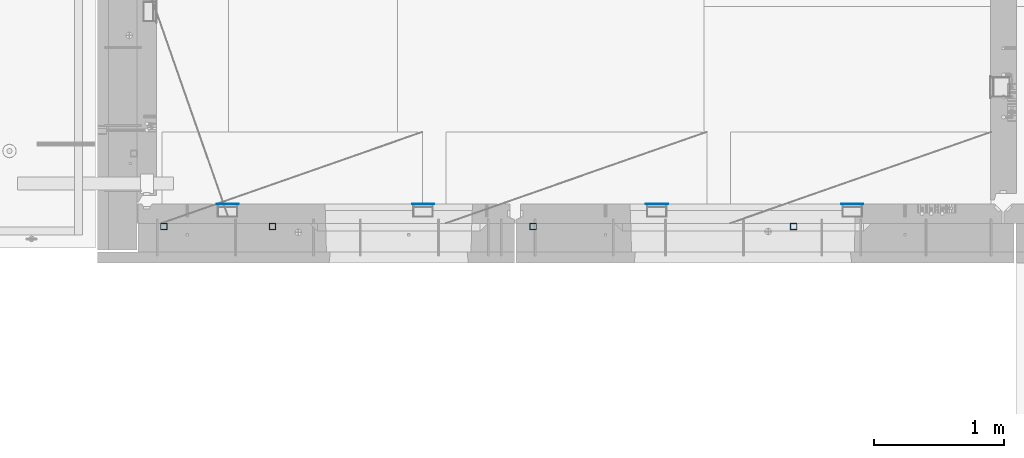
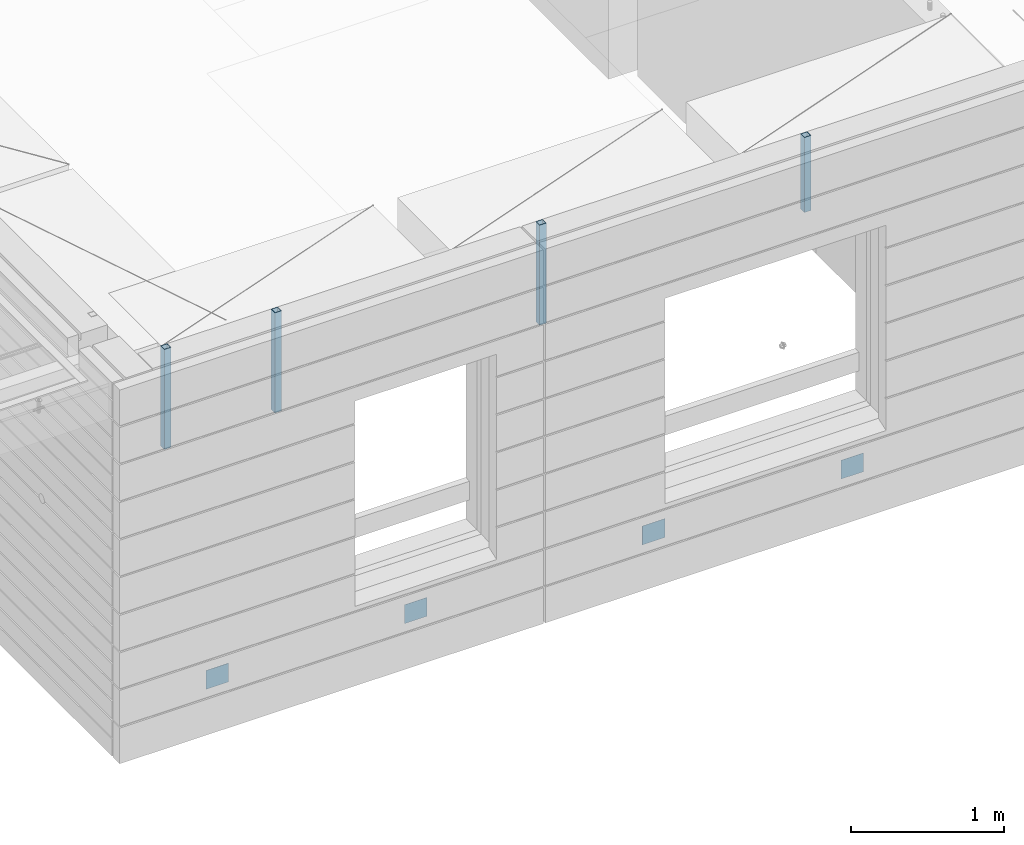
# One storey, part 9 of 349: 8 columns, 10 elements without a shape of their own.
"""IFC2X3 building model written with IfcOpenShell, lengths in millimetres."""

from ifc_helpers import new_model, si_unit, frame, origin_with_axes, place, context, subcontext, project, spatial, faceted_brep, material, type_object, element, aggregate, save


model = new_model("IFC2X3")

# Units and contexts
model_context = context("Model", 3, precision=1e-05, world=origin_with_axes())
body_context = subcontext(model_context, "Body", "Model", "MODEL_VIEW")
ifc_project = project(units=[si_unit("LENGTHUNIT", "METRE", prefix="MILLI"), si_unit("AREAUNIT", "SQUARE_METRE"), si_unit("VOLUMEUNIT", "CUBIC_METRE"), si_unit("MASSUNIT", "GRAM", prefix="KILO"), si_unit("TIMEUNIT", "SECOND"), si_unit("PLANEANGLEUNIT", "RADIAN"), si_unit("SOLIDANGLEUNIT", "STERADIAN"), si_unit("THERMODYNAMICTEMPERATUREUNIT", "DEGREE_CELSIUS"), si_unit("LUMINOUSINTENSITYUNIT", "LUMEN")], contexts=[model_context])

# Site, building, storey
site_placement = place(None, origin_with_axes())
site = spatial("IfcSite", under=ifc_project, at=site_placement, CompositionType="ELEMENT")
building_placement = place(site_placement, origin_with_axes())
building = spatial("IfcBuilding", under=site, at=building_placement, CompositionType="ELEMENT")
storey_placement = place(building_placement, origin_with_axes())
storey = spatial("IfcBuildingStorey", under=building, at=storey_placement, Name="4", CompositionType="ELEMENT", Elevation=0.0)

# Assemblies, columns
assembly_1_placement = place(storey_placement, origin_with_axes())
assembly_1 = element("IfcElementAssembly", 1, at=assembly_1_placement, inside=storey, AssemblyPlace="NOTDEFINED", PredefinedType="REINFORCEMENT_UNIT")
assembly_2_placement = place(assembly_1_placement, origin_with_axes())
assembly_2 = element("IfcElementAssembly", 2, at=assembly_2_placement, Name="Steel Assembly", AssemblyPlace="NOTDEFINED", PredefinedType="NOTDEFINED")
ifc_material_1 = material(Name="Undefined")
column_type_1 = type_object("IfcColumnType", PredefinedType="NOTDEFINED")
column_1_placement = place(assembly_2_placement, frame((10705.0, 7999.00000000618, 90755.0), z_axis=(0.0, 1.0, 0.0), x_axis=(0.0, 0.0, 1.0)))
column_1 = element("IfcColumn", 3, at=column_1_placement, type_object=column_type_1, material=ifc_material_1, Name="SPK2", context=body_context, shape_type="Brep", body=[
    faceted_brep([(0.0, 85.0, -1.0), (0.0, 85.0, 1.0), (150.0, 85.0, 1.0), (150.0, 85.0, -1.0), (0.0, -85.0, 1.0), (150.0, -85.0, 1.0), (0.0, -85.0, -1.0), (150.0, -85.0, -1.0)], [[[0, 1, 2, 3]], [[1, 4, 5, 2]], [[4, 6, 7, 5]], [[6, 0, 3, 7]], [[5, 7, 3, 2]], [[6, 4, 1, 0]]]),
])
aggregate(assembly_2, [column_1])
assembly_3_placement = place(assembly_1_placement, origin_with_axes())
assembly_3 = element("IfcElementAssembly", 4, at=assembly_3_placement, Name="Steel Assembly", AssemblyPlace="NOTDEFINED", PredefinedType="NOTDEFINED")
column_2_placement = place(assembly_3_placement, frame((12205.0, 7999.00000000618, 90755.0), z_axis=(0.0, 1.0, 0.0), x_axis=(0.0, 0.0, 1.0)))
column_2 = element("IfcColumn", 5, at=column_2_placement, type_object=column_type_1, material=ifc_material_1, Name="SPK2", context=body_context, shape_type="Brep", body=[
    faceted_brep([(0.0, 85.0, -1.0), (0.0, 85.0, 1.0), (150.0, 85.0, 1.0), (150.0, 85.0, -1.0), (0.0, -85.0, 1.0), (150.0, -85.0, 1.0), (0.0, -85.0, -1.0), (150.0, -85.0, -1.0)], [[[0, 1, 2, 3]], [[1, 4, 5, 2]], [[4, 6, 7, 5]], [[6, 0, 3, 7]], [[5, 7, 3, 2]], [[6, 4, 1, 0]]]),
])
aggregate(assembly_3, [column_2])

assembly_4_placement = place(storey_placement, origin_with_axes())
assembly_4 = element("IfcElementAssembly", 6, at=assembly_4_placement, inside=storey, AssemblyPlace="NOTDEFINED", PredefinedType="REINFORCEMENT_UNIT")
assembly_5_placement = place(assembly_4_placement, origin_with_axes())
assembly_5 = element("IfcElementAssembly", 7, at=assembly_5_placement, Name="Steel Assembly", AssemblyPlace="NOTDEFINED", PredefinedType="NOTDEFINED")
column_3_placement = place(assembly_5_placement, frame((14000.0, 7999.00000000618, 90755.0), z_axis=(0.0, 1.0, 0.0), x_axis=(0.0, 0.0, 1.0)))
column_3 = element("IfcColumn", 8, at=column_3_placement, type_object=column_type_1, material=ifc_material_1, Name="SPK2", context=body_context, shape_type="Brep", body=[
    faceted_brep([(0.0, 85.0, -1.0), (0.0, 85.0, 1.0), (150.0, 85.0, 1.0), (150.0, 85.0, -1.0), (0.0, -85.0, 1.0), (150.0, -85.0, 1.0), (0.0, -85.0, -1.0), (150.0, -85.0, -1.0)], [[[0, 1, 2, 3]], [[1, 4, 5, 2]], [[4, 6, 7, 5]], [[6, 0, 3, 7]], [[5, 7, 3, 2]], [[6, 4, 1, 0]]]),
])
aggregate(assembly_5, [column_3])
assembly_6_placement = place(assembly_4_placement, origin_with_axes())
assembly_6 = element("IfcElementAssembly", 9, at=assembly_6_placement, Name="Steel Assembly", AssemblyPlace="NOTDEFINED", PredefinedType="NOTDEFINED")
column_4_placement = place(assembly_6_placement, frame((15500.0, 7998.99999999844, 90754.9999999985), z_axis=(0.0, 1.0, 0.0), x_axis=(0.0, 0.0, 1.0)))
column_4 = element("IfcColumn", 10, at=column_4_placement, type_object=column_type_1, material=ifc_material_1, Name="SPK2", context=body_context, shape_type="Brep", body=[
    faceted_brep([(0.0, 85.0, -1.0), (0.0, 85.0, 1.0), (150.0, 85.0, 1.0), (150.0, 85.0, -1.0), (0.0, -85.0, 1.0), (150.0, -85.0, 1.0), (0.0, -85.0, -1.0), (150.0, -85.0, -1.0)], [[[0, 1, 2, 3]], [[1, 4, 5, 2]], [[4, 6, 7, 5]], [[6, 0, 3, 7]], [[5, 7, 3, 2]], [[6, 4, 1, 0]]]),
])
aggregate(assembly_6, [column_4])

# Assembly, column
assembly_7_placement = place(assembly_1_placement, origin_with_axes())
assembly_7 = element("IfcElementAssembly", 11, at=assembly_7_placement, Name="Steel Assembly", AssemblyPlace="NOTDEFINED", PredefinedType="RIGID_FRAME")
ifc_material_2 = material(Name="STEEL/S355J2")
column_type_2 = type_object("IfcColumnType", Name="50X50X3", PredefinedType="NOTDEFINED")
column_5_placement = place(assembly_7_placement, frame((11050.0, 7825.0, 92940.0), z_axis=(-1.0, 3.00000001838171e-08, 0.0), x_axis=(0.0, 0.0, 1.0)))
column_5 = element("IfcColumn", 12, at=column_5_placement, type_object=column_type_2, material=ifc_material_2, ObjectType="50X50X3", context=body_context, shape_type="Brep", body=[
    faceted_brep([(0.0, 22.0, -22.0), (0.0, -22.0, -22.0), (800.0, -22.0, -22.0), (800.0, 22.0, -22.0), (0.0, -22.0, 22.0), (800.0, -22.0, 22.0), (0.0, 22.0, 22.0), (800.0, 22.0, 22.0), (0.0, 25.0, -25.0), (0.0, 25.0, 25.0), (800.0, 25.0, 25.0), (800.0, 25.0, -25.0), (0.0, -25.0, 25.0), (800.0, -25.0, 25.0), (0.0, -25.0, -25.0), (800.0, -25.0, -25.0)], [[[0, 1, 2, 3]], [[1, 4, 5, 2]], [[4, 6, 7, 5]], [[6, 0, 3, 7]], [[8, 9, 10, 11]], [[9, 12, 13, 10]], [[12, 14, 15, 13]], [[14, 8, 11, 15]], [[13, 15, 11, 10], [5, 7, 3, 2]], [[14, 12, 9, 8], [6, 4, 1, 0]]]),
])
aggregate(assembly_7, [column_5])

# Assembly
assembly_8_placement = place(assembly_1_placement, origin_with_axes())
assembly_8 = element("IfcElementAssembly", 13, at=assembly_8_placement, Name="Steel Assembly", AssemblyPlace="NOTDEFINED", PredefinedType="RIGID_FRAME")

aggregate(assembly_1, [assembly_2, assembly_3, assembly_7, assembly_8])

# Column
column_6_placement = place(assembly_8_placement, frame((10215.0, 7825.0, 92940.0), z_axis=(-1.0, 3.00000001838171e-08, 0.0), x_axis=(0.0, 0.0, 1.0)))
column_6 = element("IfcColumn", 14, at=column_6_placement, type_object=column_type_2, material=ifc_material_2, ObjectType="50X50X3", context=body_context, shape_type="Brep", body=[
    faceted_brep([(0.0, 22.0, -22.0), (0.0, -22.0, -22.0), (800.0, -22.0, -22.0), (800.0, 22.0, -22.0), (0.0, -22.0, 22.0), (800.0, -22.0, 22.0), (0.0, 22.0, 22.0), (800.0, 22.0, 22.0), (0.0, 25.0, -25.0), (0.0, 25.0, 25.0), (800.0, 25.0, 25.0), (800.0, 25.0, -25.0), (0.0, -25.0, 25.0), (800.0, -25.0, 25.0), (0.0, -25.0, -25.0), (800.0, -25.0, -25.0)], [[[0, 1, 2, 3]], [[1, 4, 5, 2]], [[4, 6, 7, 5]], [[6, 0, 3, 7]], [[8, 9, 10, 11]], [[9, 12, 13, 10]], [[12, 14, 15, 13]], [[14, 8, 11, 15]], [[13, 15, 11, 10], [5, 7, 3, 2]], [[14, 12, 9, 8], [6, 4, 1, 0]]]),
])

aggregate(assembly_8, [column_6])

# Assembly, column
assembly_9_placement = place(assembly_4_placement, origin_with_axes())
assembly_9 = element("IfcElementAssembly", 15, at=assembly_9_placement, Name="Steel Assembly", AssemblyPlace="NOTDEFINED", PredefinedType="RIGID_FRAME")
column_7_placement = place(assembly_9_placement, frame((15050.0, 7825.0, 93140.0), z_axis=(-1.0, 3.00000001838171e-08, 0.0), x_axis=(0.0, 0.0, 1.0)))
column_7 = element("IfcColumn", 16, at=column_7_placement, type_object=column_type_2, material=ifc_material_2, ObjectType="50X50X3", context=body_context, shape_type="Brep", body=[
    faceted_brep([(0.0, 22.0, -22.0), (0.0, -22.0, -22.0), (600.0, -22.0, -22.0), (600.0, 22.0, -22.0), (0.0, -22.0, 22.0), (600.0, -22.0, 22.0), (0.0, 22.0, 22.0), (600.0, 22.0, 22.0), (0.0, 25.0, -25.0), (0.0, 25.0, 25.0), (600.0, 25.0, 25.0), (600.0, 25.0, -25.0), (0.0, -25.0, 25.0), (600.0, -25.0, 25.0), (0.0, -25.0, -25.0), (600.0, -25.0, -25.0)], [[[0, 1, 2, 3]], [[1, 4, 5, 2]], [[4, 6, 7, 5]], [[6, 0, 3, 7]], [[8, 9, 10, 11]], [[9, 12, 13, 10]], [[12, 14, 15, 13]], [[14, 8, 11, 15]], [[13, 15, 11, 10], [5, 7, 3, 2]], [[14, 12, 9, 8], [6, 4, 1, 0]]]),
])
aggregate(assembly_9, [column_7])

# Assembly
assembly_10_placement = place(assembly_4_placement, origin_with_axes())
assembly_10 = element("IfcElementAssembly", 17, at=assembly_10_placement, Name="Steel Assembly", AssemblyPlace="NOTDEFINED", PredefinedType="RIGID_FRAME")

aggregate(assembly_4, [assembly_5, assembly_6, assembly_9, assembly_10])

# Column
column_8_placement = place(assembly_10_placement, frame((13050.0, 7825.0, 92940.0), z_axis=(-1.0, 3.00000001838171e-08, 0.0), x_axis=(0.0, 0.0, 1.0)))
column_8 = element("IfcColumn", 18, at=column_8_placement, type_object=column_type_2, material=ifc_material_2, ObjectType="50X50X3", context=body_context, shape_type="Brep", body=[
    faceted_brep([(0.0, 22.0, -22.0), (0.0, -22.0, -22.0), (800.0, -22.0, -22.0), (800.0, 22.0, -22.0), (0.0, -22.0, 22.0), (800.0, -22.0, 22.0), (0.0, 22.0, 22.0), (800.0, 22.0, 22.0), (0.0, 25.0, -25.0), (0.0, 25.0, 25.0), (800.0, 25.0, 25.0), (800.0, 25.0, -25.0), (0.0, -25.0, 25.0), (800.0, -25.0, 25.0), (0.0, -25.0, -25.0), (800.0, -25.0, -25.0)], [[[0, 1, 2, 3]], [[1, 4, 5, 2]], [[4, 6, 7, 5]], [[6, 0, 3, 7]], [[8, 9, 10, 11]], [[9, 12, 13, 10]], [[12, 14, 15, 13]], [[14, 8, 11, 15]], [[13, 15, 11, 10], [5, 7, 3, 2]], [[14, 12, 9, 8], [6, 4, 1, 0]]]),
])

aggregate(assembly_10, [column_8])

save(model, "model.ifc")
